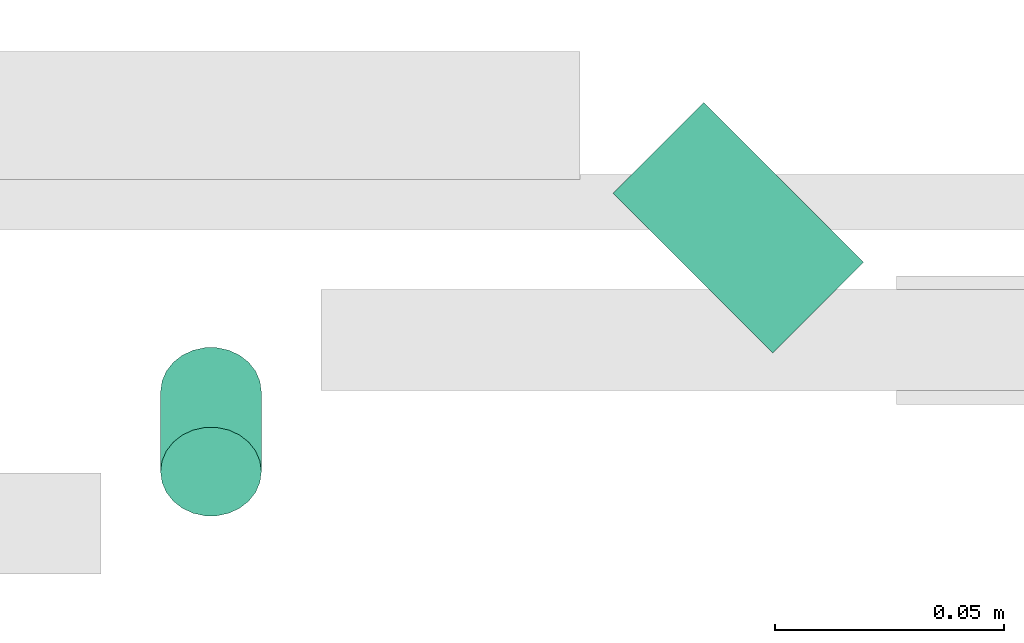
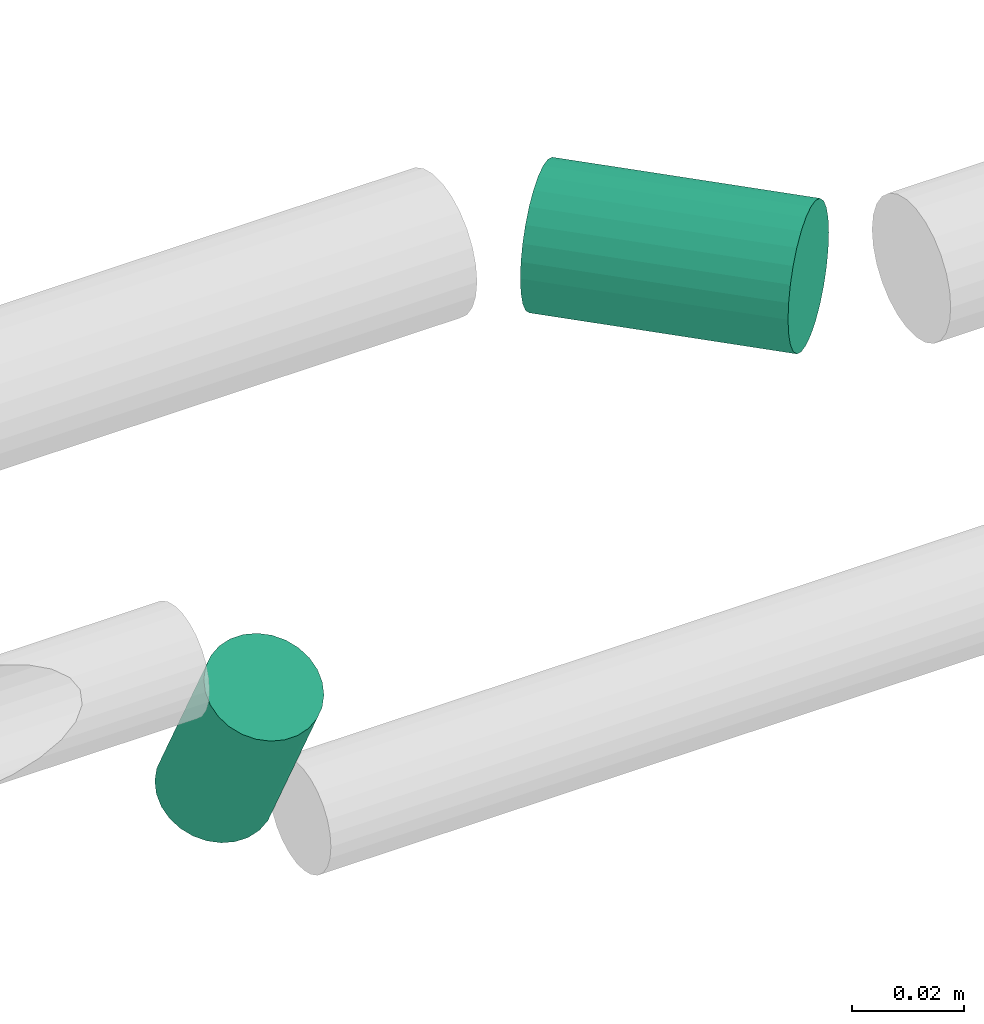
# One storey, part 281 of 331: 2 flow segments.
"""IFC2X3 building model written with IfcOpenShell, lengths in millimetres."""

from ifc_helpers import new_model, entity, si_unit, converted_unit, derived_unit, direction, frame, origin, origin_2d_with_axis, place, context, subcontext, project, spatial, circle, extrude, type_object, element, save


model = new_model("IFC2X3")

# Units and contexts
model_context = context("Model", 3, precision=0.01, world=origin(), true_north=direction((6.12303176911189e-17, 1.0)))
body_context = subcontext(model_context, "Body", "Model", "MODEL_VIEW")
ifc_project = project(units=[si_unit("LENGTHUNIT", "METRE", prefix="MILLI"), si_unit("AREAUNIT", "SQUARE_METRE"), si_unit("VOLUMEUNIT", "CUBIC_METRE"), converted_unit("PLANEANGLEUNIT", "DEGREE", entity("IfcRatioMeasure", 0.0174532925199433), si_unit("PLANEANGLEUNIT", "RADIAN"), dimensions=[0, 0, 0, 0, 0, 0, 0]), si_unit("MASSUNIT", "GRAM", prefix="KILO"), derived_unit("MASSDENSITYUNIT", [(si_unit("MASSUNIT", "GRAM", prefix="KILO"), 1), (si_unit("LENGTHUNIT", "METRE"), -3)]), derived_unit("MOMENTOFINERTIAUNIT", [(si_unit("LENGTHUNIT", "METRE"), 4)]), si_unit("TIMEUNIT", "SECOND"), si_unit("FREQUENCYUNIT", "HERTZ"), si_unit("THERMODYNAMICTEMPERATUREUNIT", "DEGREE_CELSIUS"), derived_unit("THERMALTRANSMITTANCEUNIT", [(si_unit("MASSUNIT", "GRAM", prefix="KILO"), 1), (si_unit("THERMODYNAMICTEMPERATUREUNIT", "KELVIN"), -1), (si_unit("TIMEUNIT", "SECOND"), -3)]), derived_unit("VOLUMETRICFLOWRATEUNIT", [(si_unit("LENGTHUNIT", "METRE"), 3), (si_unit("TIMEUNIT", "SECOND"), -1)]), derived_unit("MASSFLOWRATEUNIT", [(si_unit("MASSUNIT", "GRAM", prefix="KILO"), 1), (si_unit("TIMEUNIT", "SECOND"), -1)]), derived_unit("ROTATIONALFREQUENCYUNIT", [(si_unit("TIMEUNIT", "SECOND"), -1)]), si_unit("ELECTRICCURRENTUNIT", "AMPERE"), si_unit("ELECTRICVOLTAGEUNIT", "VOLT"), si_unit("POWERUNIT", "WATT"), si_unit("FORCEUNIT", "NEWTON", prefix="KILO"), si_unit("ILLUMINANCEUNIT", "LUX"), si_unit("LUMINOUSFLUXUNIT", "LUMEN"), si_unit("LUMINOUSINTENSITYUNIT", "CANDELA"), derived_unit("USERDEFINED", [(si_unit("MASSUNIT", "GRAM", prefix="KILO"), -1), (si_unit("LENGTHUNIT", "METRE"), -2), (si_unit("TIMEUNIT", "SECOND"), 3), (si_unit("LUMINOUSFLUXUNIT", "LUMEN"), 1)]), derived_unit("LINEARVELOCITYUNIT", [(si_unit("LENGTHUNIT", "METRE"), 1), (si_unit("TIMEUNIT", "SECOND"), -1)]), si_unit("PRESSUREUNIT", "PASCAL"), derived_unit("USERDEFINED", [(si_unit("LENGTHUNIT", "METRE"), -2), (si_unit("MASSUNIT", "GRAM", prefix="KILO"), 1), (si_unit("TIMEUNIT", "SECOND"), -2)]), derived_unit("LINEARFORCEUNIT", [(si_unit("MASSUNIT", "GRAM", prefix="KILO"), 1), (si_unit("LENGTHUNIT", "METRE"), 1), (si_unit("TIMEUNIT", "SECOND"), -2), (si_unit("LENGTHUNIT", "METRE"), -1)]), derived_unit("PLANARFORCEUNIT", [(si_unit("MASSUNIT", "GRAM", prefix="KILO"), 1), (si_unit("LENGTHUNIT", "METRE"), 1), (si_unit("TIMEUNIT", "SECOND"), -2), (si_unit("LENGTHUNIT", "METRE"), -2)])], contexts=[model_context])

# Site, building, storey
site_placement = place(None, frame((0.0, -0.00077364408347762, 0.0)))
site = spatial("IfcSite", under=ifc_project, at=site_placement, CompositionType="ELEMENT")
building_placement = place(site_placement, origin())
building = spatial("IfcBuilding", under=site, at=building_placement, CompositionType="ELEMENT")
storey_placement = place(building_placement, origin())
storey = spatial("IfcBuildingStorey", under=building, at=storey_placement, CompositionType="ELEMENT", Elevation=0.0)

# Flow segments
pipe_segment_type = type_object("IfcPipeSegmentType", PredefinedType="NOTDEFINED")
flow_segment_1_placement = place(building_placement, frame((47635.9406740869, 8191.09256233187, 2759.40472776402)))
element("IfcFlowSegment", 1, at=flow_segment_1_placement, inside=storey, type_object=pipe_segment_type, context=body_context, shape_type="SweptSolid", body=[
    extrude(circle(Radius=14.0, at=origin_2d_with_axis()), frame((11.4947671725293, 46.3526315488058, 15.595272235916), z_axis=(0.707106781186427, -0.707106781186668, 0.0), x_axis=(0.707106781186668, 0.707106781186427, 0.0)), (0.0, 0.0, 1.0), 49.2964645562883),
])
flow_segment_2_placement = place(building_placement, frame((47537.2030577144, 8155.50922475086, 2714.40472776403)))
element("IfcFlowSegment", 2, at=flow_segment_2_placement, inside=storey, type_object=pipe_segment_type, context=body_context, shape_type="SweptSolid", body=[
    extrude(circle(Radius=11.0, at=origin_2d_with_axis()), frame((12.5952722359134, 28.7129192947407, 6.77174282415406), z_axis=(0.0, -0.470588235294312, 0.882352941176367), x_axis=(-1.0, 0.0, 0.0)), (0.0, 0.0, 1.0), 36.9999999999901),
])

save(model, "model.ifc")
